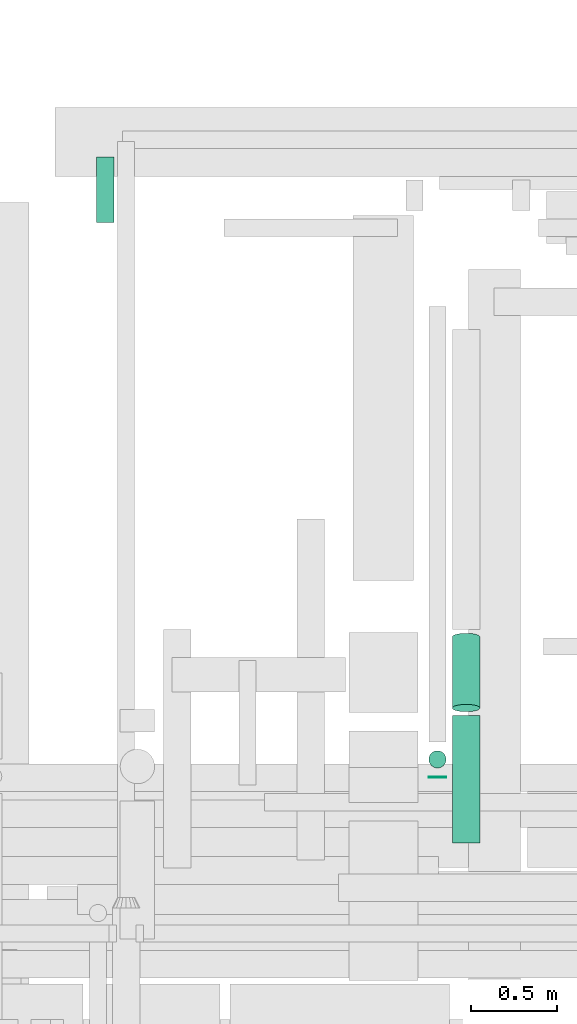
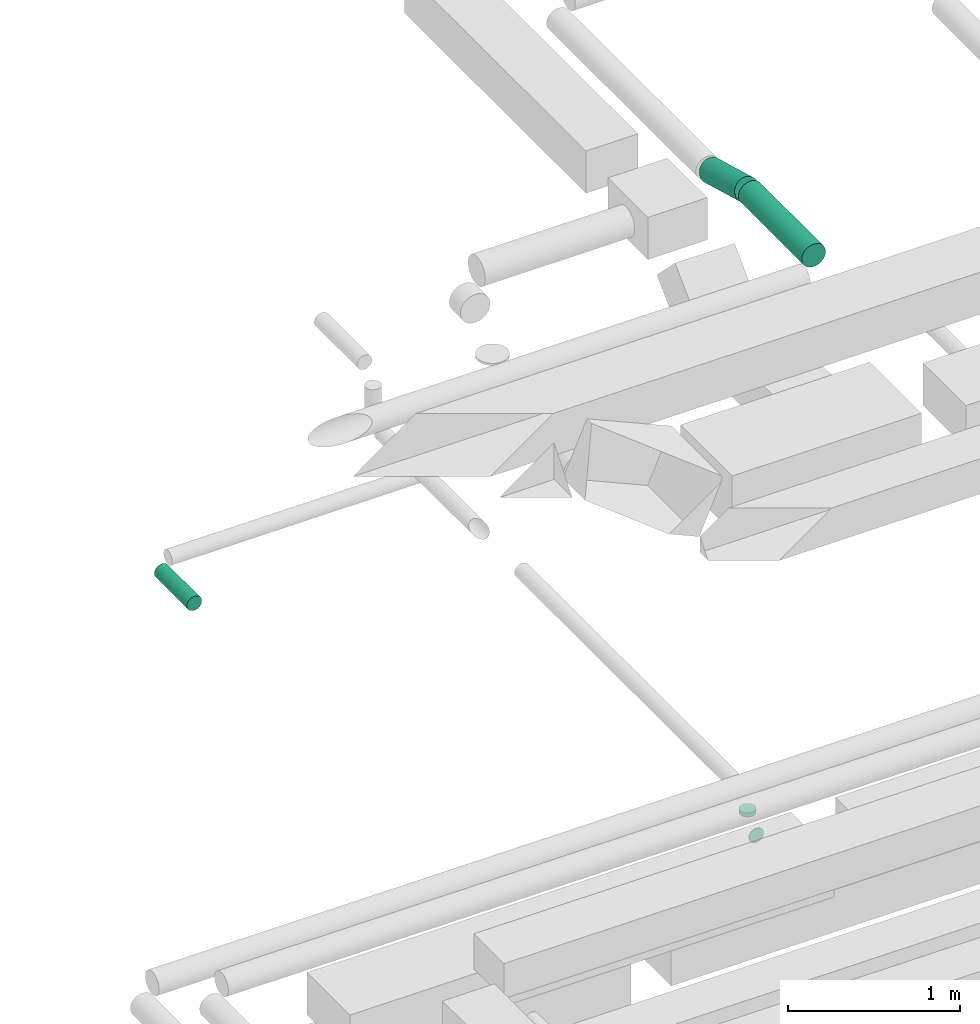
# One storey, part 152 of 337: 5 flow segments.
"""IFC2X3 building model written with IfcOpenShell, lengths in millimetres."""

import ifcopenshell
import ifcopenshell.guid

model = None  # the IFC model being written
_history = None  # IfcOwnerHistory: only IFC2X3 demands one
_inside = {}  # id of a spatial element -> (the spatial element, [elements in it])
_under = {}  # id of a project, library or spatial element -> (it, [spatial elements below it])
_declared = {}  # id of a project -> (the project, [libraries it declares])
_typed = {}  # id of a type object -> (the type object, [elements of that type])
_made_of = {}  # id of a material, layer set ... -> (it, [elements and type objects made of it])


def new_model(schema):
    """Start an empty IFC model of exactly this schema.

    Asked for "IFC4X3", IfcOpenShell would pick the latest addendum, in which some entities
    have other attributes; the version numbers below select the first issue.
    IFC2X3 requires an IfcOwnerHistory on every rooted entity: one is made here for all.
    """
    global model, _history
    if schema == "IFC4X3":
        model = ifcopenshell.file(schema_version=(4, 3, 0, 0))
    else:
        model = ifcopenshell.file(schema=schema)
    _inside.clear()
    _under.clear()
    _declared.clear()
    _typed.clear()
    _made_of.clear()
    _history = None
    if model.schema == "IFC2X3":
        org = make("IfcOrganization", Name="unknown")
        user = make(
            "IfcPersonAndOrganization",
            ThePerson=make("IfcPerson", FamilyName="unknown"),
            TheOrganization=org,
        )
        app = make(
            "IfcApplication",
            ApplicationDeveloper=org,
            Version="unknown",
            ApplicationFullName="unknown",
            ApplicationIdentifier="unknown",
        )
        _history = make(
            "IfcOwnerHistory",
            OwningUser=user,
            OwningApplication=app,
            ChangeAction="ADDED",
            CreationDate=0,
        )
    return model


def make(cls, **values):
    """One entity of the class cls with the attributes given. An attribute that is None is left unset."""
    return model.create_entity(
        cls, **{name: value for name, value in values.items() if value is not None}
    )


def entity(cls, *values):
    """Any entity or typed value of the class cls, its attributes in the order of the schema. None: left unset."""
    e = model.create_entity(cls)
    for i, value in enumerate(values):
        if value is not None:
            e[i] = value
    return e


def rooted(cls, **values):
    """An entity with a GlobalId (a new one), such as an element, a storey or a relation."""
    return make(cls, GlobalId=ifcopenshell.guid.new(), OwnerHistory=_history, **values)


def si_unit(unit_type, name, prefix=None):
    """IfcSIUnit, for example si_unit("LENGTHUNIT", "METRE", prefix="MILLI")."""
    return make("IfcSIUnit", UnitType=unit_type, Prefix=prefix, Name=name)


def converted_unit(unit_type, name, factor, base, dimensions=None, offset=None):
    """IfcConversionBasedUnit, such as the inch: factor (a typed value) times the base unit."""
    return make(
        "IfcConversionBasedUnit"
        if offset is None
        else "IfcConversionBasedUnitWithOffset",
        ConversionOffset=offset,
        Dimensions=None
        if dimensions is None
        else entity("IfcDimensionalExponents", *dimensions),
        UnitType=unit_type,
        Name=name,
        ConversionFactor=make(
            "IfcMeasureWithUnit", ValueComponent=factor, UnitComponent=base
        ),
    )


def derived_unit(unit_type, elements):
    """IfcDerivedUnit: a product of units, each with its exponent."""
    return make(
        "IfcDerivedUnit",
        Elements=[
            make("IfcDerivedUnitElement", Unit=unit, Exponent=power)
            for unit, power in elements
        ],
        UnitType=unit_type,
    )


def assignment(units):
    """IfcUnitAssignment: the units of a project."""
    return None if units is None else make("IfcUnitAssignment", Units=units)


def point(xyz):
    """IfcCartesianPoint."""
    return None if xyz is None else make("IfcCartesianPoint", Coordinates=xyz)


def direction(xyz):
    """IfcDirection."""
    return None if xyz is None else make("IfcDirection", DirectionRatios=xyz)


def frame(location, z_axis=None, x_axis=None):
    """IfcAxis2Placement3D, a coordinate frame: its origin and axes. An axis left out is left unset."""
    return make(
        "IfcAxis2Placement3D",
        Location=point(location),
        Axis=direction(z_axis),
        RefDirection=direction(x_axis),
    )


def frame_2d(location, x_axis=None):
    """IfcAxis2Placement2D, a coordinate frame in the plane: its origin and x axis."""
    return make(
        "IfcAxis2Placement2D", Location=point(location), RefDirection=direction(x_axis)
    )


def origin():
    """The frame at (0, 0, 0) with its axes left unset."""
    return frame((0.0, 0.0, 0.0))


def origin_2d_with_axis():
    """The frame at (0, 0) in the plane with the x axis (1, 0) written out."""
    return frame_2d((0.0, 0.0), x_axis=(1.0, 0.0))


def place(relative_to, where):
    """IfcLocalPlacement: puts the frame where relative to a parent placement (None: the world)."""
    return make(
        "IfcLocalPlacement", PlacementRelTo=relative_to, RelativePlacement=where
    )


def context(
    kind, dimensions, precision=None, world=None, true_north=None, identifier=None
):
    """IfcGeometricRepresentationContext, for example the 3D "Model" context."""
    return make(
        "IfcGeometricRepresentationContext",
        ContextIdentifier=identifier,
        ContextType=kind,
        CoordinateSpaceDimension=dimensions,
        Precision=precision,
        WorldCoordinateSystem=world,
        TrueNorth=true_north,
    )


def subcontext(parent, identifier, kind, view, scale=None):
    """IfcGeometricRepresentationSubContext, for example "Body" below "Model"."""
    return make(
        "IfcGeometricRepresentationSubContext",
        ContextIdentifier=identifier,
        ContextType=kind,
        ParentContext=parent,
        TargetScale=scale,
        TargetView=view,
    )


def project(units=None, contexts=None):
    """IfcProject with its units and contexts."""
    return rooted(
        "IfcProject",
        Name="project",
        RepresentationContexts=contexts,
        UnitsInContext=assignment(units),
    )


def spatial(cls, under=None, at=None, **own):
    """A site, building, storey or space (cls), placed at a placement, below another one or the project."""
    s = rooted(cls, ObjectPlacement=at, **own)
    if under is not None:
        _under.setdefault(under.id(), (under, []))[1].append(s)
    return s


def profile(cls, at=None, kind="AREA", **sizes):
    """A parametric profile (cls). Its sizes go by their IFC names, for example OverallWidth=200.0."""
    return make(cls, ProfileType=kind, Position=at, **sizes)


def circle(**sizes):
    """IfcCircleProfileDef."""
    return profile("IfcCircleProfileDef", **sizes)


def extrude(swept, where, along, depth):
    """IfcExtrudedAreaSolid: the profile swept, set in the frame where, extruded along a direction by depth."""
    return make(
        "IfcExtrudedAreaSolid",
        SweptArea=swept,
        Position=where,
        ExtrudedDirection=direction(along),
        Depth=depth,
    )


def shape(context_of_items, identifier, shape_type, items):
    """IfcShapeRepresentation: the items that make up one representation, for example the "Body"."""
    return make(
        "IfcShapeRepresentation",
        ContextOfItems=context_of_items,
        RepresentationIdentifier=identifier,
        RepresentationType=shape_type,
        Items=items,
    )


def made_of(thing, what):
    """Note that an element or type object is made of a material, layer set ...; save() writes the relation."""
    if what is not None:
        _made_of.setdefault(what.id(), (what, []))[1].append(thing)
    return thing


def type_object(cls, material=None, **own):
    """A type object (cls), such as IfcWallType, which elements share."""
    return made_of(rooted(cls, **own), material)


def element(
    cls,
    number,
    at=None,
    inside=None,
    cuts=None,
    type_object=None,
    material=None,
    context=None,
    identifier="Body",
    shape_type=None,
    held_by="IfcProductDefinitionShape",
    body=None,
    shapes=None,
    **own,
):
    """One element of the class cls, such as IfcWall. Its Tag is "e" and its number.

    at: its placement. inside: the storey or other place that contains it. cuts: it is an
    opening in that element (IfcRelVoidsElement). A single representation is given by context,
    identifier, shape_type and body (its items); several are given by shapes. held_by: the class
    of the entity that holds the representations. save() writes the other relations.
    """
    e = rooted(cls, Tag="e%d" % number, ObjectPlacement=at, **own)
    if body is not None:
        shapes = [shape(context, identifier, shape_type, body)]
    if shapes is not None:
        e.Representation = make(held_by, Representations=shapes)
    if inside is not None:
        _inside.setdefault(inside.id(), (inside, []))[1].append(e)
    if cuts is not None:
        rooted(
            "IfcRelVoidsElement", RelatingBuildingElement=cuts, RelatedOpeningElement=e
        )
    if type_object is not None:
        _typed.setdefault(type_object.id(), (type_object, []))[1].append(e)
    return made_of(e, material)


def aggregate(whole, parts):
    """IfcRelAggregates: a whole, such as a stair, and the parts it consists of."""
    return rooted("IfcRelAggregates", RelatingObject=whole, RelatedObjects=parts)


def save(model, path):
    """Write the relations noted so far, then the file.

    IfcRelAggregates (storeys below a building ...), IfcRelContainedInSpatialStructure (elements
    in a storey), IfcRelDefinesByType, IfcRelAssociatesMaterial and IfcRelDeclares: one each for
    every whole, place, type object, material and project.
    """
    for whole, parts in _under.values():
        aggregate(whole, parts)
    for where, things in _inside.values():
        rooted(
            "IfcRelContainedInSpatialStructure",
            RelatedElements=things,
            RelatingStructure=where,
        )
    for kind, things in _typed.values():
        rooted("IfcRelDefinesByType", RelatedObjects=things, RelatingType=kind)
    for what, things in _made_of.values():
        rooted("IfcRelAssociatesMaterial", RelatedObjects=things, RelatingMaterial=what)
    for by, libraries in _declared.values():
        rooted("IfcRelDeclares", RelatingContext=by, RelatedDefinitions=libraries)
    model.write(path)


model = new_model("IFC2X3")

# Units and contexts
model_context = context("Model", 3, precision=0.01, world=origin(), true_north=direction((6.12303176911189e-17, 1.0)))
body_context = subcontext(model_context, "Body", "Model", "MODEL_VIEW")
ifc_project = project(units=[si_unit("LENGTHUNIT", "METRE", prefix="MILLI"), si_unit("AREAUNIT", "SQUARE_METRE"), si_unit("VOLUMEUNIT", "CUBIC_METRE"), converted_unit("PLANEANGLEUNIT", "DEGREE", entity("IfcRatioMeasure", 0.0174532925199433), si_unit("PLANEANGLEUNIT", "RADIAN"), dimensions=[0, 0, 0, 0, 0, 0, 0]), si_unit("MASSUNIT", "GRAM", prefix="KILO"), derived_unit("MASSDENSITYUNIT", [(si_unit("MASSUNIT", "GRAM", prefix="KILO"), 1), (si_unit("LENGTHUNIT", "METRE"), -3)]), derived_unit("MOMENTOFINERTIAUNIT", [(si_unit("LENGTHUNIT", "METRE"), 4)]), si_unit("TIMEUNIT", "SECOND"), si_unit("FREQUENCYUNIT", "HERTZ"), si_unit("THERMODYNAMICTEMPERATUREUNIT", "DEGREE_CELSIUS"), derived_unit("THERMALTRANSMITTANCEUNIT", [(si_unit("MASSUNIT", "GRAM", prefix="KILO"), 1), (si_unit("THERMODYNAMICTEMPERATUREUNIT", "KELVIN"), -1), (si_unit("TIMEUNIT", "SECOND"), -3)]), derived_unit("VOLUMETRICFLOWRATEUNIT", [(si_unit("LENGTHUNIT", "METRE"), 3), (si_unit("TIMEUNIT", "SECOND"), -1)]), derived_unit("MASSFLOWRATEUNIT", [(si_unit("MASSUNIT", "GRAM", prefix="KILO"), 1), (si_unit("TIMEUNIT", "SECOND"), -1)]), derived_unit("ROTATIONALFREQUENCYUNIT", [(si_unit("TIMEUNIT", "SECOND"), -1)]), si_unit("ELECTRICCURRENTUNIT", "AMPERE"), si_unit("ELECTRICVOLTAGEUNIT", "VOLT"), si_unit("POWERUNIT", "WATT"), si_unit("FORCEUNIT", "NEWTON", prefix="KILO"), si_unit("ILLUMINANCEUNIT", "LUX"), si_unit("LUMINOUSFLUXUNIT", "LUMEN"), si_unit("LUMINOUSINTENSITYUNIT", "CANDELA"), derived_unit("USERDEFINED", [(si_unit("MASSUNIT", "GRAM", prefix="KILO"), -1), (si_unit("LENGTHUNIT", "METRE"), -2), (si_unit("TIMEUNIT", "SECOND"), 3), (si_unit("LUMINOUSFLUXUNIT", "LUMEN"), 1)]), derived_unit("LINEARVELOCITYUNIT", [(si_unit("LENGTHUNIT", "METRE"), 1), (si_unit("TIMEUNIT", "SECOND"), -1)]), si_unit("PRESSUREUNIT", "PASCAL"), derived_unit("USERDEFINED", [(si_unit("LENGTHUNIT", "METRE"), -2), (si_unit("MASSUNIT", "GRAM", prefix="KILO"), 1), (si_unit("TIMEUNIT", "SECOND"), -2)]), derived_unit("LINEARFORCEUNIT", [(si_unit("MASSUNIT", "GRAM", prefix="KILO"), 1), (si_unit("LENGTHUNIT", "METRE"), 1), (si_unit("TIMEUNIT", "SECOND"), -2), (si_unit("LENGTHUNIT", "METRE"), -1)]), derived_unit("PLANARFORCEUNIT", [(si_unit("MASSUNIT", "GRAM", prefix="KILO"), 1), (si_unit("LENGTHUNIT", "METRE"), 1), (si_unit("TIMEUNIT", "SECOND"), -2), (si_unit("LENGTHUNIT", "METRE"), -2)])], contexts=[model_context])

# Site, building, storey
site_placement = place(None, origin())
site = spatial("IfcSite", under=ifc_project, at=site_placement, CompositionType="ELEMENT")
building_placement = place(site_placement, origin())
building = spatial("IfcBuilding", under=site, at=building_placement, CompositionType="ELEMENT")
storey_placement = place(building_placement, origin())
storey = spatial("IfcBuildingStorey", under=building, at=storey_placement, CompositionType="ELEMENT", Elevation=0.0)

# Flow segments
duct_segment_type = type_object("IfcDuctSegmentType", PredefinedType="NOTDEFINED")
flow_segment_1_placement = place(storey_placement, frame((21193.27, 15841.41, 19188.4)))
element("IfcFlowSegment", 1, at=flow_segment_1_placement, inside=storey, type_object=duct_segment_type, context=body_context, shape_type="SweptSolid", body=[
    extrude(circle(Radius=80.0, at=origin_2d_with_axis()), frame((81.6, 0.0, 81.6), z_axis=(0.0, 1.0, 0.0), x_axis=(1.0, 0.0, 0.0)), (0.0, 0.0, 1.0), 738.364410081884),
])
flow_segment_2_placement = place(storey_placement, frame((21193.27, 16599.42, 19072.02)))
element("IfcFlowSegment", 2, at=flow_segment_2_placement, inside=storey, type_object=duct_segment_type, context=body_context, shape_type="SweptSolid", body=[
    extrude(circle(Radius=80.0, at=origin_2d_with_axis()), frame((81.6, 22.84, 192.23), z_axis=(0.0, 0.964086467864434, -0.26558855864039), x_axis=(1.0, 0.0, 0.0)), (0.0, 0.0, 1.0), 427.381624787284),
])
flow_segment_3_placement = place(storey_placement, frame((21056.76, 16220.0, 14923.4)))
element("IfcFlowSegment", 3, at=flow_segment_3_placement, inside=storey, type_object=duct_segment_type, context=body_context, shape_type="SweptSolid", body=[
    extrude(circle(Radius=50.0, at=origin_2d_with_axis()), frame((51.6, 0.0, 51.6), z_axis=(0.0, 1.0, 0.0), x_axis=(1.0, 0.0, 0.0)), (0.0, 0.0, 1.0), 4.99999999998803),
])
flow_segment_4_placement = place(storey_placement, frame((21056.76, 16273.41, 15075.0)))
element("IfcFlowSegment", 4, at=flow_segment_4_placement, inside=storey, type_object=duct_segment_type, context=body_context, shape_type="SweptSolid", body=[
    extrude(circle(Radius=50.0, at=origin_2d_with_axis()), frame((51.6, 51.6, 0.0), z_axis=(0.0, 0.0, 1.0), x_axis=(0.0, 1.0, 0.0)), (0.0, 0.0, 1.0), 30.0000000000148),
])
flow_segment_5_placement = place(storey_placement, frame((19132.55, 19433.88, 15298.4)))
element("IfcFlowSegment", 5, at=flow_segment_5_placement, inside=storey, type_object=duct_segment_type, context=body_context, shape_type="SweptSolid", body=[
    extrude(circle(Radius=50.0, at=origin_2d_with_axis()), frame((51.6, 0.0, 51.6), z_axis=(0.0, 1.0, 0.0), x_axis=(-1.0, 0.0, 0.0)), (0.0, 0.0, 1.0), 380.000000000009),
])

save(model, "model.ifc")
